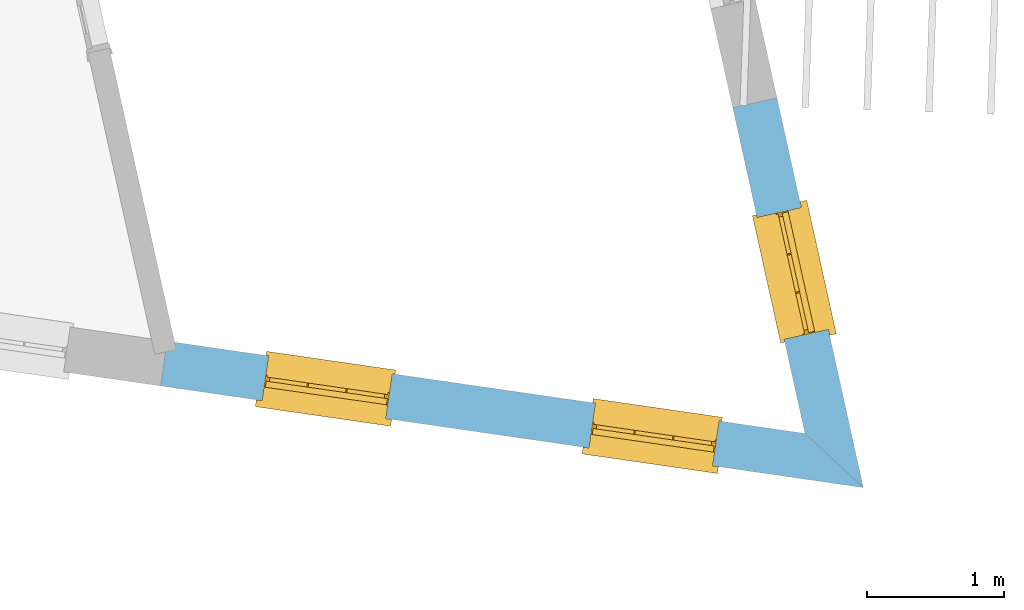
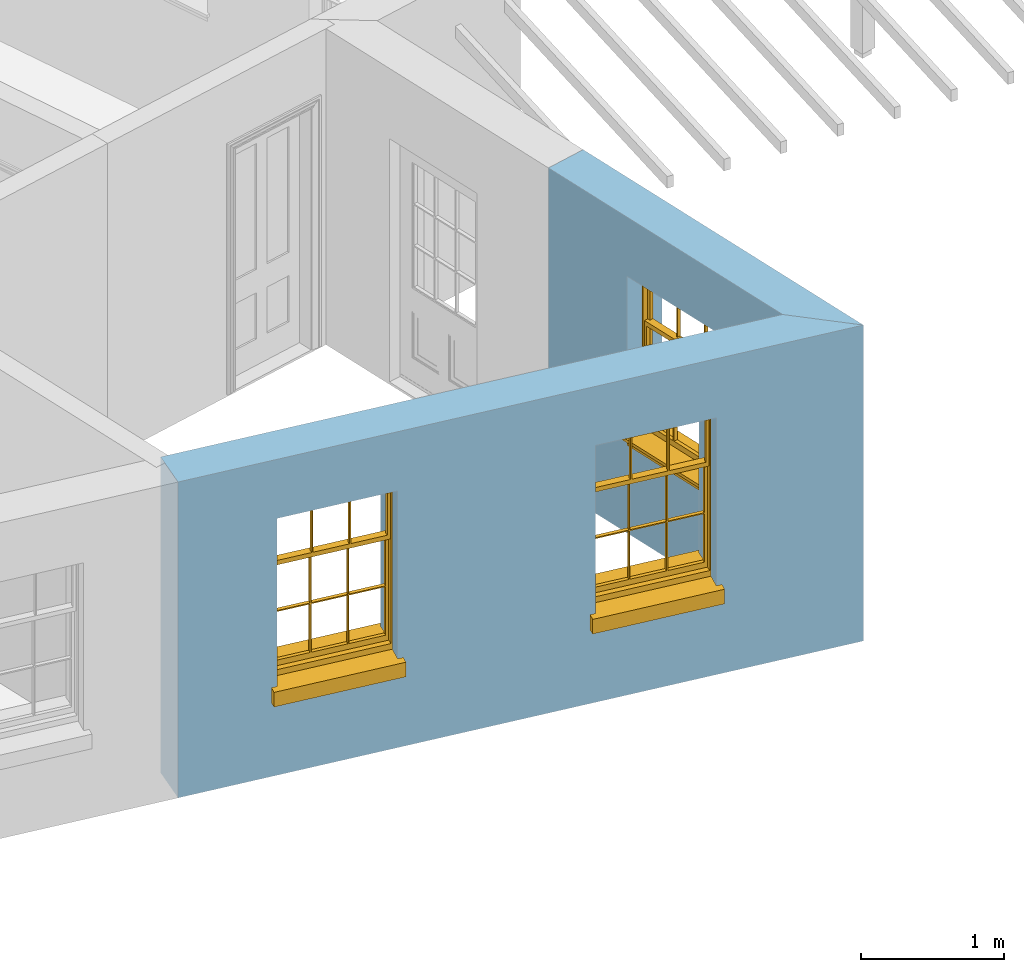
# One storey, part 5 of 11: 3 windows, 3 openings, plus 2 elements that do not belong to this part.
"""IFC2X3 building model written with IfcOpenShell, lengths in metres."""

from ifc_helpers import new_model, si_unit, frame, origin, place, context, subcontext, project, spatial, polyline, outline, extrude, faceted_brep, material, layer, layer_set, layer_usage, element, fill, save


model = new_model("IFC2X3")

# Units and contexts
model_context = context("Model", 3, world=origin())
body_context = subcontext(model_context, "Body", "Model", "MODEL_VIEW")
ifc_project = project(units=[si_unit("PLANEANGLEUNIT", "RADIAN"), si_unit("MASSUNIT", "GRAM", prefix="KILO"), si_unit("FORCEUNIT", "NEWTON", prefix="KILO"), si_unit("LENGTHUNIT", "METRE")], contexts=[model_context])

# Site, building, storey
site_placement = place(None, origin())
site = spatial("IfcSite", under=ifc_project, at=site_placement, CompositionType="ELEMENT")
building_placement = place(None, origin())
building = spatial("IfcBuilding", under=site, at=building_placement, Name="Building plot-16", CompositionType="ELEMENT")
storey_placement = place(None, frame((0.0, 0.0, 9.0)))
storey = spatial("IfcBuildingStorey", under=building, at=storey_placement, Name="Floor 2", CompositionType="ELEMENT", Elevation=9.0)

# Wall, opening, window
ifc_material = material(Name="Masonry")
ifc_layer = layer(ifc_material, 0.33, ventilated=False)
ifc_layer_set = layer_set([ifc_layer], Name="My Wall")
ifc_layer_usage = layer_usage(ifc_layer_set, "AXIS2", "NEGATIVE", 0.08)
wall_1_placement = place(storey_placement, origin())
wall_1 = element("IfcWallStandardCase", 1, at=wall_1_placement, inside=storey, material=ifc_layer_usage, Name="exterior", context=body_context, shape_type="SweptSolid", body=[
    extrude(outline(polyline([(97.1549084446968, 30.7413476988825), (97.5805288405461, 30.3463147311604), (96.9516649800753, 33.1820737328336), (96.6294918891393, 33.110627952855), (97.1549084446968, 30.7413476988825)])), origin(), (0.0, 0.0, 1.0), 2.7),
])
opening_1_placement = place(storey_placement, frame((0.0, 0.0, 0.75)))
opening_1 = element("IfcOpeningElement", 2, at=opening_1_placement, cuts=wall_1, Name="Opening", ObjectType="Opening", context=body_context, shape_type="SweptSolid", body=[
    extrude(outline(polyline([(97.3254209005413, 31.496682374684), (97.1284037496912, 32.3850990799923), (96.8062306587552, 32.3136533000138), (97.0032478096053, 31.4252365947054), (97.3254209005413, 31.496682374684)])), origin(), (0.0, 0.0, 1.0), 1.445),
])
window_1_placement = place(storey_placement, frame((97.0813503771049, 31.4425567837911, 0.75), z_axis=(0.0, 0.0, 1.0), x_axis=(-0.197017150850044, 0.888416705308341, 0.0)))
window_1 = element("IfcWindow", 3, at=window_1_placement, inside=storey, Name="circulation outside window", OverallHeight=1.445, OverallWidth=0.91, context=body_context, shape_type="Brep", held_by="IfcProductRepresentation", body=[
    faceted_brep([(0.876875, -0.105, 0.999097), (0.876875, -0.105, 1.411875), (0.9, -0.105, 1.435), (0.033125, -0.105, 1.411875), (0.033125, -0.105, 0.999097), (0.01, -0.105, 1.435), (0.033125, -0.135, 1.411875), (0.01, -0.135, 1.435), (0.033125, -0.135, 0.999097), (0.876875, -0.135, 1.411875), (0.876875, -0.135, 0.999097), (0.9, -0.135, 1.435), (0.033125, -0.105, 0.960972), (0.01, -0.105, 0.960972), (0.033125, -0.105, 0.548195), (0.876875, -0.105, 0.960972), (0.876875, -0.105, 0.548195), (0.9, -0.105, 0.960972), (0.876875, -0.105, 0.538195), (0.876875, -0.105, 0.125417), (0.9, -0.105, 0.077167), (0.033125, -0.105, 0.125417), (0.033125, -0.105, 0.538195), (0.01, -0.105, 0.077167), (0.9, -0.135, 0.960972), (0.01, -0.135, 0.960972), (-0.0425, -0.25, 0.01), (-0.0425, -0.3, 0.001667), (0.0, -0.25, 0.01), (0.9525, -0.25, 0.01), (0.91, -0.25, 0.01), (0.9525, -0.3, 0.001667), (-0.02, 0.08, 0.077167), (0.0, 0.08, 0.077167), (-0.02, 0.11, 0.077167), (0.0, -0.06, 0.077167), (0.01, -0.06, 0.077167), (0.91, -0.06, 0.077167), (0.91, 0.08, 0.077167), (0.9, -0.06, 0.077167), (0.93, 0.08, 0.077167), (0.93, 0.11, 0.077167), (0.01, -0.105, 0.999097), (0.01, -0.075, 0.999097), (0.9, -0.105, 0.999097), (0.9, -0.075, 0.999097), (0.876875, -0.075, 0.125417), (0.876875, -0.075, 0.538195), (0.9, -0.075, 0.077167), (0.876875, -0.075, 0.548195), (0.876875, -0.075, 0.960972), (0.033125, -0.075, 0.125417), (0.01, -0.075, 0.077167), (0.033125, -0.075, 0.538195), (0.033125, -0.075, 0.960972), (0.033125, -0.075, 0.548195), (-0.02, 0.08, 0.052167), (-0.02, 0.11, 0.052167), (0.93, 0.11, 0.052167), (0.93, 0.08, 0.052167), (0.91, 0.08, 0.052167), (0.0, 0.08, 0.052167), (0.91, -0.15, 0.026667), (0.0, -0.15, 0.026667), (-0.0425, -0.3, -0.123333), (0.9525, -0.3, -0.123333), (-0.0425, -0.25, -0.123333), (0.9525, -0.25, -0.123333), (0.01, -0.06, 1.435), (0.9, -0.06, 1.435), (0.0, -0.06, 1.445), (0.91, -0.06, 1.445), (0.01, -0.15, 0.077167), (0.9, -0.15, 0.077167), (0.592292, -0.105, 0.125417), (0.592292, -0.075, 0.125417), (0.317708, -0.075, 0.125417), (0.317708, -0.105, 0.125417), (0.592292, -0.105, 0.548195), (0.317708, -0.105, 0.548195), (0.317708, -0.105, 0.538195), (0.592292, -0.105, 0.538195), (0.592292, -0.075, 0.548195), (0.317708, -0.075, 0.548195), (0.602292, -0.075, 0.548195), (0.602292, -0.105, 0.548195), (0.317708, -0.075, 0.538195), (0.307708, -0.075, 0.125417), (0.307708, -0.075, 0.538195), (0.602292, -0.075, 0.538195), (0.602292, -0.075, 0.125417), (0.592292, -0.075, 0.538195), (0.307708, -0.075, 0.548195), (0.317708, -0.075, 0.960972), (0.307708, -0.075, 0.960972), (0.602292, -0.075, 0.960972), (0.592292, -0.075, 0.960972), (0.307708, -0.105, 0.538195), (0.307708, -0.105, 0.125417), (0.307708, -0.105, 0.548195), (0.307708, -0.105, 0.960972), (0.592292, -0.105, 0.960972), (0.317708, -0.105, 0.960972), (0.602292, -0.105, 0.960972), (0.602292, -0.105, 0.538195), (0.602292, -0.105, 0.125417), (0.317708, -0.135, 1.411875), (0.307708, -0.135, 1.411875), (0.307708, -0.135, 0.999097), (0.317708, -0.135, 0.999097), (0.602292, -0.135, 1.411875), (0.592292, -0.135, 1.411875), (0.592292, -0.135, 0.999097), (0.602292, -0.135, 0.999097), (0.317708, -0.105, 0.999097), (0.307708, -0.105, 0.999097), (0.307708, -0.105, 1.411875), (0.317708, -0.105, 1.411875), (0.602292, -0.105, 0.999097), (0.592292, -0.105, 0.999097), (0.592292, -0.105, 1.411875), (0.602292, -0.105, 1.411875), (0.91, -0.15, 1.445), (0.9, -0.15, 1.435), (0.01, -0.15, 1.435), (0.0, -0.15, 1.445), (0.91, -0.25, 0.0), (0.0, -0.25, 0.0), (0.91, 0.08, 0.0), (0.0, 0.08, 0.0)], [[[0, 1, 2]], [[3, 4, 5]], [[6, 7, 8]], [[9, 10, 11]], [[12, 13, 14]], [[15, 16, 17]], [[18, 19, 20]], [[21, 22, 23]], [[24, 15, 17]], [[13, 12, 25]], [[26, 27, 28]], [[29, 30, 31]], [[32, 33, 34]], [[35, 36, 33]], [[37, 38, 39]], [[40, 41, 38]], [[42, 4, 43]], [[44, 45, 0]], [[46, 47, 48]], [[49, 50, 45]], [[51, 52, 53]], [[54, 55, 43]], [[38, 33, 36, 39]], [[41, 34, 33, 38]], [[56, 32, 34, 57]], [[57, 34, 41, 58]], [[58, 41, 40, 59]], [[57, 58, 60, 61]], [[52, 48, 39, 36]], [[62, 63, 28, 30]], [[27, 31, 30, 28]], [[27, 64, 65, 31]], [[66, 67, 65, 64]], [[2, 5, 68, 69]], [[68, 70, 71, 69]], [[20, 23, 72, 73]], [[73, 72, 63, 62]], [[74, 75, 76, 77]], [[78, 79, 80, 81]], [[78, 82, 83, 79]], [[16, 49, 84, 85]], [[86, 76, 87, 88]], [[89, 90, 75, 91]], [[92, 88, 53, 55]], [[82, 91, 86, 83]], [[93, 83, 92, 94]], [[95, 84, 82, 96]], [[89, 84, 49, 47]], [[97, 88, 87, 98]], [[22, 53, 88, 97]], [[81, 91, 75, 74]], [[80, 86, 91, 81]], [[77, 76, 86, 80]], [[99, 92, 55, 14]], [[100, 94, 92, 99]], [[101, 96, 82, 78]], [[79, 83, 93, 102]], [[85, 84, 95, 103]], [[104, 89, 47, 18]], [[105, 90, 89, 104]], [[104, 18, 16, 85]], [[80, 97, 98, 77]], [[104, 81, 74, 105]], [[103, 101, 78, 85]], [[99, 14, 22, 97]], [[102, 100, 99, 79]], [[106, 107, 108, 109]], [[110, 111, 112, 113]], [[114, 115, 116, 117]], [[118, 119, 120, 121]], [[107, 116, 115, 108]], [[111, 120, 119, 112]], [[109, 114, 117, 106]], [[113, 118, 121, 110]], [[85, 78, 81, 104]], [[84, 89, 91, 82]], [[83, 86, 88, 92]], [[79, 99, 97, 80]], [[109, 112, 119, 114]], [[102, 93, 96, 101]], [[106, 117, 120, 111]], [[98, 87, 51, 21]], [[6, 3, 116, 107]], [[110, 121, 1, 9]], [[19, 46, 90, 105]], [[26, 66, 64, 27]], [[29, 31, 65, 67]], [[25, 24, 112, 109]], [[11, 7, 106, 111]], [[75, 48, 52, 76]], [[43, 45, 96, 93]], [[45, 43, 114, 119]], [[5, 2, 120, 117]], [[24, 25, 102, 101]], [[42, 5, 4]], [[2, 44, 0]], [[49, 45, 48, 47]], [[52, 43, 55, 53]], [[14, 13, 23, 22]], [[20, 17, 16, 18]], [[24, 11, 10]], [[25, 8, 7]], [[8, 4, 3, 6]], [[9, 1, 0, 10]], [[15, 50, 49, 16]], [[18, 47, 46, 19]], [[21, 51, 53, 22]], [[14, 55, 54, 12]], [[44, 2, 69, 45]], [[68, 5, 42, 43]], [[36, 35, 70, 68]], [[39, 69, 71, 37]], [[62, 122, 123, 73]], [[63, 72, 124, 125]], [[8, 108, 115, 4]], [[113, 10, 0, 118]], [[94, 100, 12, 54]], [[17, 20, 73, 24]], [[72, 23, 13, 25]], [[52, 36, 68, 43]], [[69, 39, 48, 45]], [[11, 24, 73, 123]], [[7, 124, 72, 25]], [[23, 77, 98]], [[98, 21, 23]], [[105, 74, 20]], [[20, 19, 105]], [[20, 74, 77, 23]], [[113, 112, 24]], [[24, 10, 113]], [[25, 109, 108]], [[108, 8, 25]], [[110, 9, 11]], [[11, 111, 110]], [[7, 6, 107]], [[107, 106, 7]], [[5, 117, 116]], [[116, 3, 5]], [[121, 120, 2]], [[2, 1, 121]], [[11, 123, 124, 7]], [[122, 125, 124, 123]], [[43, 93, 94]], [[94, 54, 43]], [[96, 45, 95]], [[50, 95, 45]], [[15, 103, 95, 50]], [[48, 75, 90]], [[90, 46, 48]], [[87, 76, 52]], [[52, 51, 87]], [[103, 15, 24]], [[24, 101, 103]], [[100, 102, 25]], [[25, 12, 100]], [[115, 114, 43]], [[43, 4, 115]], [[118, 0, 45]], [[45, 119, 118]], [[71, 70, 125, 122]], [[70, 35, 63, 125]], [[122, 62, 37, 71]], [[126, 67, 66, 127]], [[60, 58, 59]], [[38, 60, 59, 40]], [[61, 56, 57]], [[32, 56, 61, 33]], [[61, 60, 128, 129]], [[62, 60, 38, 37]], [[126, 128, 60, 62]], [[33, 61, 63, 35]], [[61, 129, 127, 63]], [[128, 126, 127, 129]], [[28, 127, 66, 26]], [[63, 127, 28]], [[29, 67, 126, 30]], [[30, 126, 62]]]),
])
fill(opening_1, window_1)

# Wall, openings, windows
wall_2_placement = place(storey_placement, origin())
wall_2 = element("IfcWallStandardCase", 4, at=wall_2_placement, inside=storey, material=ifc_layer_usage, Name="exterior", context=body_context, shape_type="SweptSolid", body=[
    extrude(outline(polyline([(92.513960177979, 31.4129793647637), (92.4666954104416, 31.086381689099), (97.5805288405461, 30.3463147311604), (97.1549084446968, 30.7413476988825), (92.513960177979, 31.4129793647637)])), origin(), (0.0, 0.0, 1.0), 2.7),
])
opening_2_placement = place(storey_placement, frame((0.0, 0.0, 0.75)))
opening_2 = element("IfcOpeningElement", 5, at=opening_2_placement, cuts=wall_2, Name="Opening", ObjectType="Opening", context=body_context, shape_type="SweptSolid", body=[
    extrude(outline(polyline([(93.2052832675461, 30.979494267745), (94.1059011004399, 30.8491580905963), (94.1531658679773, 31.1757557662611), (93.2525480350835, 31.3060919434098), (93.2052832675461, 30.979494267745)])), origin(), (0.0, 0.0, 1.0), 1.445),
])
opening_3_placement = place(storey_placement, frame((0.0, 0.0, 0.75)))
opening_3 = element("IfcOpeningElement", 6, at=opening_3_placement, cuts=wall_2, Name="Opening", ObjectType="Opening", context=body_context, shape_type="SweptSolid", body=[
    extrude(outline(polyline([(95.5830768146488, 30.6353832478883), (96.4836946475426, 30.5050470707397), (96.53095941508, 30.8316447464044), (95.6303415821863, 30.9619809235531), (95.5830768146488, 30.6353832478883)])), origin(), (0.0, 0.0, 1.0), 1.445),
])
window_2_placement = place(storey_placement, frame((93.2410899096199, 31.2269167493092, 0.75), z_axis=(0.0, 0.0, 1.0), x_axis=(0.900617832893772, -0.130336177148674, 0.0)))
window_2 = element("IfcWindow", 7, at=window_2_placement, inside=storey, Name="circulation outside window", OverallHeight=1.445, OverallWidth=0.91, context=body_context, shape_type="Brep", held_by="IfcProductRepresentation", body=[
    faceted_brep([(0.876875, -0.105, 0.999097), (0.876875, -0.105, 1.411875), (0.9, -0.105, 1.435), (0.033125, -0.105, 1.411875), (0.033125, -0.105, 0.999097), (0.01, -0.105, 1.435), (0.033125, -0.135, 1.411875), (0.01, -0.135, 1.435), (0.033125, -0.135, 0.999097), (0.876875, -0.135, 1.411875), (0.876875, -0.135, 0.999097), (0.9, -0.135, 1.435), (0.033125, -0.105, 0.960972), (0.01, -0.105, 0.960972), (0.033125, -0.105, 0.548195), (0.876875, -0.105, 0.960972), (0.876875, -0.105, 0.548195), (0.9, -0.105, 0.960972), (0.876875, -0.105, 0.538195), (0.876875, -0.105, 0.125417), (0.9, -0.105, 0.077167), (0.033125, -0.105, 0.125417), (0.033125, -0.105, 0.538195), (0.01, -0.105, 0.077167), (0.9, -0.135, 0.960972), (0.01, -0.135, 0.960972), (-0.0425, -0.25, 0.01), (-0.0425, -0.3, 0.001667), (0.0, -0.25, 0.01), (0.9525, -0.25, 0.01), (0.91, -0.25, 0.01), (0.9525, -0.3, 0.001667), (-0.02, 0.08, 0.077167), (0.0, 0.08, 0.077167), (-0.02, 0.11, 0.077167), (0.0, -0.06, 0.077167), (0.01, -0.06, 0.077167), (0.91, -0.06, 0.077167), (0.91, 0.08, 0.077167), (0.9, -0.06, 0.077167), (0.93, 0.08, 0.077167), (0.93, 0.11, 0.077167), (0.01, -0.105, 0.999097), (0.01, -0.075, 0.999097), (0.9, -0.105, 0.999097), (0.9, -0.075, 0.999097), (0.876875, -0.075, 0.125417), (0.876875, -0.075, 0.538195), (0.9, -0.075, 0.077167), (0.876875, -0.075, 0.548195), (0.876875, -0.075, 0.960972), (0.033125, -0.075, 0.125417), (0.01, -0.075, 0.077167), (0.033125, -0.075, 0.538195), (0.033125, -0.075, 0.960972), (0.033125, -0.075, 0.548195), (-0.02, 0.08, 0.052167), (-0.02, 0.11, 0.052167), (0.93, 0.11, 0.052167), (0.93, 0.08, 0.052167), (0.91, 0.08, 0.052167), (0.0, 0.08, 0.052167), (0.91, -0.15, 0.026667), (0.0, -0.15, 0.026667), (-0.0425, -0.3, -0.123333), (0.9525, -0.3, -0.123333), (-0.0425, -0.25, -0.123333), (0.9525, -0.25, -0.123333), (0.01, -0.06, 1.435), (0.9, -0.06, 1.435), (0.0, -0.06, 1.445), (0.91, -0.06, 1.445), (0.01, -0.15, 0.077167), (0.9, -0.15, 0.077167), (0.592292, -0.105, 0.125417), (0.592292, -0.075, 0.125417), (0.317708, -0.075, 0.125417), (0.317708, -0.105, 0.125417), (0.592292, -0.105, 0.548195), (0.317708, -0.105, 0.548195), (0.317708, -0.105, 0.538195), (0.592292, -0.105, 0.538195), (0.592292, -0.075, 0.548195), (0.317708, -0.075, 0.548195), (0.602292, -0.075, 0.548195), (0.602292, -0.105, 0.548195), (0.317708, -0.075, 0.538195), (0.307708, -0.075, 0.125417), (0.307708, -0.075, 0.538195), (0.602292, -0.075, 0.538195), (0.602292, -0.075, 0.125417), (0.592292, -0.075, 0.538195), (0.307708, -0.075, 0.548195), (0.317708, -0.075, 0.960972), (0.307708, -0.075, 0.960972), (0.602292, -0.075, 0.960972), (0.592292, -0.075, 0.960972), (0.307708, -0.105, 0.538195), (0.307708, -0.105, 0.125417), (0.307708, -0.105, 0.548195), (0.307708, -0.105, 0.960972), (0.592292, -0.105, 0.960972), (0.317708, -0.105, 0.960972), (0.602292, -0.105, 0.960972), (0.602292, -0.105, 0.538195), (0.602292, -0.105, 0.125417), (0.317708, -0.135, 1.411875), (0.307708, -0.135, 1.411875), (0.307708, -0.135, 0.999097), (0.317708, -0.135, 0.999097), (0.602292, -0.135, 1.411875), (0.592292, -0.135, 1.411875), (0.592292, -0.135, 0.999097), (0.602292, -0.135, 0.999097), (0.317708, -0.105, 0.999097), (0.307708, -0.105, 0.999097), (0.307708, -0.105, 1.411875), (0.317708, -0.105, 1.411875), (0.602292, -0.105, 0.999097), (0.592292, -0.105, 0.999097), (0.592292, -0.105, 1.411875), (0.602292, -0.105, 1.411875), (0.91, -0.15, 1.445), (0.9, -0.15, 1.435), (0.01, -0.15, 1.435), (0.0, -0.15, 1.445), (0.91, -0.25, 0.0), (0.0, -0.25, 0.0), (0.91, 0.08, 0.0), (0.0, 0.08, 0.0)], [[[0, 1, 2]], [[3, 4, 5]], [[6, 7, 8]], [[9, 10, 11]], [[12, 13, 14]], [[15, 16, 17]], [[18, 19, 20]], [[21, 22, 23]], [[24, 15, 17]], [[13, 12, 25]], [[26, 27, 28]], [[29, 30, 31]], [[32, 33, 34]], [[35, 36, 33]], [[37, 38, 39]], [[40, 41, 38]], [[42, 4, 43]], [[44, 45, 0]], [[46, 47, 48]], [[49, 50, 45]], [[51, 52, 53]], [[54, 55, 43]], [[38, 33, 36, 39]], [[41, 34, 33, 38]], [[56, 32, 34, 57]], [[57, 34, 41, 58]], [[58, 41, 40, 59]], [[57, 58, 60, 61]], [[52, 48, 39, 36]], [[62, 63, 28, 30]], [[27, 31, 30, 28]], [[27, 64, 65, 31]], [[66, 67, 65, 64]], [[2, 5, 68, 69]], [[68, 70, 71, 69]], [[20, 23, 72, 73]], [[73, 72, 63, 62]], [[74, 75, 76, 77]], [[78, 79, 80, 81]], [[78, 82, 83, 79]], [[16, 49, 84, 85]], [[86, 76, 87, 88]], [[89, 90, 75, 91]], [[92, 88, 53, 55]], [[82, 91, 86, 83]], [[93, 83, 92, 94]], [[95, 84, 82, 96]], [[89, 84, 49, 47]], [[97, 88, 87, 98]], [[22, 53, 88, 97]], [[81, 91, 75, 74]], [[80, 86, 91, 81]], [[77, 76, 86, 80]], [[99, 92, 55, 14]], [[100, 94, 92, 99]], [[101, 96, 82, 78]], [[79, 83, 93, 102]], [[85, 84, 95, 103]], [[104, 89, 47, 18]], [[105, 90, 89, 104]], [[104, 18, 16, 85]], [[80, 97, 98, 77]], [[104, 81, 74, 105]], [[103, 101, 78, 85]], [[99, 14, 22, 97]], [[102, 100, 99, 79]], [[106, 107, 108, 109]], [[110, 111, 112, 113]], [[114, 115, 116, 117]], [[118, 119, 120, 121]], [[107, 116, 115, 108]], [[111, 120, 119, 112]], [[109, 114, 117, 106]], [[113, 118, 121, 110]], [[85, 78, 81, 104]], [[84, 89, 91, 82]], [[83, 86, 88, 92]], [[79, 99, 97, 80]], [[109, 112, 119, 114]], [[102, 93, 96, 101]], [[106, 117, 120, 111]], [[98, 87, 51, 21]], [[6, 3, 116, 107]], [[110, 121, 1, 9]], [[19, 46, 90, 105]], [[26, 66, 64, 27]], [[29, 31, 65, 67]], [[25, 24, 112, 109]], [[11, 7, 106, 111]], [[75, 48, 52, 76]], [[43, 45, 96, 93]], [[45, 43, 114, 119]], [[5, 2, 120, 117]], [[24, 25, 102, 101]], [[42, 5, 4]], [[2, 44, 0]], [[49, 45, 48, 47]], [[52, 43, 55, 53]], [[14, 13, 23, 22]], [[20, 17, 16, 18]], [[24, 11, 10]], [[25, 8, 7]], [[8, 4, 3, 6]], [[9, 1, 0, 10]], [[15, 50, 49, 16]], [[18, 47, 46, 19]], [[21, 51, 53, 22]], [[14, 55, 54, 12]], [[44, 2, 69, 45]], [[68, 5, 42, 43]], [[36, 35, 70, 68]], [[39, 69, 71, 37]], [[62, 122, 123, 73]], [[63, 72, 124, 125]], [[8, 108, 115, 4]], [[113, 10, 0, 118]], [[94, 100, 12, 54]], [[17, 20, 73, 24]], [[72, 23, 13, 25]], [[52, 36, 68, 43]], [[69, 39, 48, 45]], [[11, 24, 73, 123]], [[7, 124, 72, 25]], [[23, 77, 98]], [[98, 21, 23]], [[105, 74, 20]], [[20, 19, 105]], [[20, 74, 77, 23]], [[113, 112, 24]], [[24, 10, 113]], [[25, 109, 108]], [[108, 8, 25]], [[110, 9, 11]], [[11, 111, 110]], [[7, 6, 107]], [[107, 106, 7]], [[5, 117, 116]], [[116, 3, 5]], [[121, 120, 2]], [[2, 1, 121]], [[11, 123, 124, 7]], [[122, 125, 124, 123]], [[43, 93, 94]], [[94, 54, 43]], [[96, 45, 95]], [[50, 95, 45]], [[15, 103, 95, 50]], [[48, 75, 90]], [[90, 46, 48]], [[87, 76, 52]], [[52, 51, 87]], [[103, 15, 24]], [[24, 101, 103]], [[100, 102, 25]], [[25, 12, 100]], [[115, 114, 43]], [[43, 4, 115]], [[118, 0, 45]], [[45, 119, 118]], [[71, 70, 125, 122]], [[70, 35, 63, 125]], [[122, 62, 37, 71]], [[126, 67, 66, 127]], [[60, 58, 59]], [[38, 60, 59, 40]], [[61, 56, 57]], [[32, 56, 61, 33]], [[61, 60, 128, 129]], [[62, 60, 38, 37]], [[126, 128, 60, 62]], [[33, 61, 63, 35]], [[61, 129, 127, 63]], [[128, 126, 127, 129]], [[28, 127, 66, 26]], [[63, 127, 28]], [[29, 67, 126, 30]], [[30, 126, 62]]]),
])
fill(opening_2, window_2)
window_3_placement = place(storey_placement, frame((95.6188834567226, 30.8828057294526, 0.75), z_axis=(0.0, 0.0, 1.0), x_axis=(0.900617832893772, -0.130336177148674, 0.0)))
window_3 = element("IfcWindow", 8, at=window_3_placement, inside=storey, Name="circulation outside window", OverallHeight=1.445, OverallWidth=0.91, context=body_context, shape_type="Brep", held_by="IfcProductRepresentation", body=[
    faceted_brep([(0.876875, -0.105, 0.999097), (0.876875, -0.105, 1.411875), (0.9, -0.105, 1.435), (0.033125, -0.105, 1.411875), (0.033125, -0.105, 0.999097), (0.01, -0.105, 1.435), (0.033125, -0.135, 1.411875), (0.01, -0.135, 1.435), (0.033125, -0.135, 0.999097), (0.876875, -0.135, 1.411875), (0.876875, -0.135, 0.999097), (0.9, -0.135, 1.435), (0.033125, -0.105, 0.960972), (0.01, -0.105, 0.960972), (0.033125, -0.105, 0.548195), (0.876875, -0.105, 0.960972), (0.876875, -0.105, 0.548195), (0.9, -0.105, 0.960972), (0.876875, -0.105, 0.538195), (0.876875, -0.105, 0.125417), (0.9, -0.105, 0.077167), (0.033125, -0.105, 0.125417), (0.033125, -0.105, 0.538195), (0.01, -0.105, 0.077167), (0.9, -0.135, 0.960972), (0.01, -0.135, 0.960972), (-0.0425, -0.25, 0.01), (-0.0425, -0.3, 0.001667), (0.0, -0.25, 0.01), (0.9525, -0.25, 0.01), (0.91, -0.25, 0.01), (0.9525, -0.3, 0.001667), (-0.02, 0.08, 0.077167), (0.0, 0.08, 0.077167), (-0.02, 0.11, 0.077167), (0.0, -0.06, 0.077167), (0.01, -0.06, 0.077167), (0.91, -0.06, 0.077167), (0.91, 0.08, 0.077167), (0.9, -0.06, 0.077167), (0.93, 0.08, 0.077167), (0.93, 0.11, 0.077167), (0.01, -0.105, 0.999097), (0.01, -0.075, 0.999097), (0.9, -0.105, 0.999097), (0.9, -0.075, 0.999097), (0.876875, -0.075, 0.125417), (0.876875, -0.075, 0.538195), (0.9, -0.075, 0.077167), (0.876875, -0.075, 0.548195), (0.876875, -0.075, 0.960972), (0.033125, -0.075, 0.125417), (0.01, -0.075, 0.077167), (0.033125, -0.075, 0.538195), (0.033125, -0.075, 0.960972), (0.033125, -0.075, 0.548195), (-0.02, 0.08, 0.052167), (-0.02, 0.11, 0.052167), (0.93, 0.11, 0.052167), (0.93, 0.08, 0.052167), (0.91, 0.08, 0.052167), (0.0, 0.08, 0.052167), (0.91, -0.15, 0.026667), (0.0, -0.15, 0.026667), (-0.0425, -0.3, -0.123333), (0.9525, -0.3, -0.123333), (-0.0425, -0.25, -0.123333), (0.9525, -0.25, -0.123333), (0.01, -0.06, 1.435), (0.9, -0.06, 1.435), (0.0, -0.06, 1.445), (0.91, -0.06, 1.445), (0.01, -0.15, 0.077167), (0.9, -0.15, 0.077167), (0.592292, -0.105, 0.125417), (0.592292, -0.075, 0.125417), (0.317708, -0.075, 0.125417), (0.317708, -0.105, 0.125417), (0.592292, -0.105, 0.548195), (0.317708, -0.105, 0.548195), (0.317708, -0.105, 0.538195), (0.592292, -0.105, 0.538195), (0.592292, -0.075, 0.548195), (0.317708, -0.075, 0.548195), (0.602292, -0.075, 0.548195), (0.602292, -0.105, 0.548195), (0.317708, -0.075, 0.538195), (0.307708, -0.075, 0.125417), (0.307708, -0.075, 0.538195), (0.602292, -0.075, 0.538195), (0.602292, -0.075, 0.125417), (0.592292, -0.075, 0.538195), (0.307708, -0.075, 0.548195), (0.317708, -0.075, 0.960972), (0.307708, -0.075, 0.960972), (0.602292, -0.075, 0.960972), (0.592292, -0.075, 0.960972), (0.307708, -0.105, 0.538195), (0.307708, -0.105, 0.125417), (0.307708, -0.105, 0.548195), (0.307708, -0.105, 0.960972), (0.592292, -0.105, 0.960972), (0.317708, -0.105, 0.960972), (0.602292, -0.105, 0.960972), (0.602292, -0.105, 0.538195), (0.602292, -0.105, 0.125417), (0.317708, -0.135, 1.411875), (0.307708, -0.135, 1.411875), (0.307708, -0.135, 0.999097), (0.317708, -0.135, 0.999097), (0.602292, -0.135, 1.411875), (0.592292, -0.135, 1.411875), (0.592292, -0.135, 0.999097), (0.602292, -0.135, 0.999097), (0.317708, -0.105, 0.999097), (0.307708, -0.105, 0.999097), (0.307708, -0.105, 1.411875), (0.317708, -0.105, 1.411875), (0.602292, -0.105, 0.999097), (0.592292, -0.105, 0.999097), (0.592292, -0.105, 1.411875), (0.602292, -0.105, 1.411875), (0.91, -0.15, 1.445), (0.9, -0.15, 1.435), (0.01, -0.15, 1.435), (0.0, -0.15, 1.445), (0.91, -0.25, 0.0), (0.0, -0.25, 0.0), (0.91, 0.08, 0.0), (0.0, 0.08, 0.0)], [[[0, 1, 2]], [[3, 4, 5]], [[6, 7, 8]], [[9, 10, 11]], [[12, 13, 14]], [[15, 16, 17]], [[18, 19, 20]], [[21, 22, 23]], [[24, 15, 17]], [[13, 12, 25]], [[26, 27, 28]], [[29, 30, 31]], [[32, 33, 34]], [[35, 36, 33]], [[37, 38, 39]], [[40, 41, 38]], [[42, 4, 43]], [[44, 45, 0]], [[46, 47, 48]], [[49, 50, 45]], [[51, 52, 53]], [[54, 55, 43]], [[38, 33, 36, 39]], [[41, 34, 33, 38]], [[56, 32, 34, 57]], [[57, 34, 41, 58]], [[58, 41, 40, 59]], [[57, 58, 60, 61]], [[52, 48, 39, 36]], [[62, 63, 28, 30]], [[27, 31, 30, 28]], [[27, 64, 65, 31]], [[66, 67, 65, 64]], [[2, 5, 68, 69]], [[68, 70, 71, 69]], [[20, 23, 72, 73]], [[73, 72, 63, 62]], [[74, 75, 76, 77]], [[78, 79, 80, 81]], [[78, 82, 83, 79]], [[16, 49, 84, 85]], [[86, 76, 87, 88]], [[89, 90, 75, 91]], [[92, 88, 53, 55]], [[82, 91, 86, 83]], [[93, 83, 92, 94]], [[95, 84, 82, 96]], [[89, 84, 49, 47]], [[97, 88, 87, 98]], [[22, 53, 88, 97]], [[81, 91, 75, 74]], [[80, 86, 91, 81]], [[77, 76, 86, 80]], [[99, 92, 55, 14]], [[100, 94, 92, 99]], [[101, 96, 82, 78]], [[79, 83, 93, 102]], [[85, 84, 95, 103]], [[104, 89, 47, 18]], [[105, 90, 89, 104]], [[104, 18, 16, 85]], [[80, 97, 98, 77]], [[104, 81, 74, 105]], [[103, 101, 78, 85]], [[99, 14, 22, 97]], [[102, 100, 99, 79]], [[106, 107, 108, 109]], [[110, 111, 112, 113]], [[114, 115, 116, 117]], [[118, 119, 120, 121]], [[107, 116, 115, 108]], [[111, 120, 119, 112]], [[109, 114, 117, 106]], [[113, 118, 121, 110]], [[85, 78, 81, 104]], [[84, 89, 91, 82]], [[83, 86, 88, 92]], [[79, 99, 97, 80]], [[109, 112, 119, 114]], [[102, 93, 96, 101]], [[106, 117, 120, 111]], [[98, 87, 51, 21]], [[6, 3, 116, 107]], [[110, 121, 1, 9]], [[19, 46, 90, 105]], [[26, 66, 64, 27]], [[29, 31, 65, 67]], [[25, 24, 112, 109]], [[11, 7, 106, 111]], [[75, 48, 52, 76]], [[43, 45, 96, 93]], [[45, 43, 114, 119]], [[5, 2, 120, 117]], [[24, 25, 102, 101]], [[42, 5, 4]], [[2, 44, 0]], [[49, 45, 48, 47]], [[52, 43, 55, 53]], [[14, 13, 23, 22]], [[20, 17, 16, 18]], [[24, 11, 10]], [[25, 8, 7]], [[8, 4, 3, 6]], [[9, 1, 0, 10]], [[15, 50, 49, 16]], [[18, 47, 46, 19]], [[21, 51, 53, 22]], [[14, 55, 54, 12]], [[44, 2, 69, 45]], [[68, 5, 42, 43]], [[36, 35, 70, 68]], [[39, 69, 71, 37]], [[62, 122, 123, 73]], [[63, 72, 124, 125]], [[8, 108, 115, 4]], [[113, 10, 0, 118]], [[94, 100, 12, 54]], [[17, 20, 73, 24]], [[72, 23, 13, 25]], [[52, 36, 68, 43]], [[69, 39, 48, 45]], [[11, 24, 73, 123]], [[7, 124, 72, 25]], [[23, 77, 98]], [[98, 21, 23]], [[105, 74, 20]], [[20, 19, 105]], [[20, 74, 77, 23]], [[113, 112, 24]], [[24, 10, 113]], [[25, 109, 108]], [[108, 8, 25]], [[110, 9, 11]], [[11, 111, 110]], [[7, 6, 107]], [[107, 106, 7]], [[5, 117, 116]], [[116, 3, 5]], [[121, 120, 2]], [[2, 1, 121]], [[11, 123, 124, 7]], [[122, 125, 124, 123]], [[43, 93, 94]], [[94, 54, 43]], [[96, 45, 95]], [[50, 95, 45]], [[15, 103, 95, 50]], [[48, 75, 90]], [[90, 46, 48]], [[87, 76, 52]], [[52, 51, 87]], [[103, 15, 24]], [[24, 101, 103]], [[100, 102, 25]], [[25, 12, 100]], [[115, 114, 43]], [[43, 4, 115]], [[118, 0, 45]], [[45, 119, 118]], [[71, 70, 125, 122]], [[70, 35, 63, 125]], [[122, 62, 37, 71]], [[126, 67, 66, 127]], [[60, 58, 59]], [[38, 60, 59, 40]], [[61, 56, 57]], [[32, 56, 61, 33]], [[61, 60, 128, 129]], [[62, 60, 38, 37]], [[126, 128, 60, 62]], [[33, 61, 63, 35]], [[61, 129, 127, 63]], [[128, 126, 127, 129]], [[28, 127, 66, 26]], [[63, 127, 28]], [[29, 67, 126, 30]], [[30, 126, 62]]]),
])
fill(opening_3, window_3)

save(model, "model.ifc")
